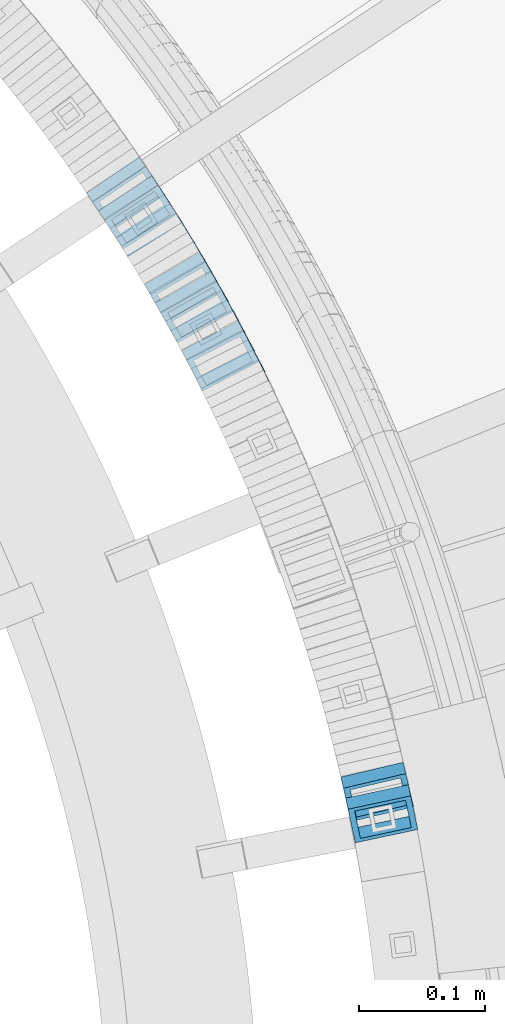
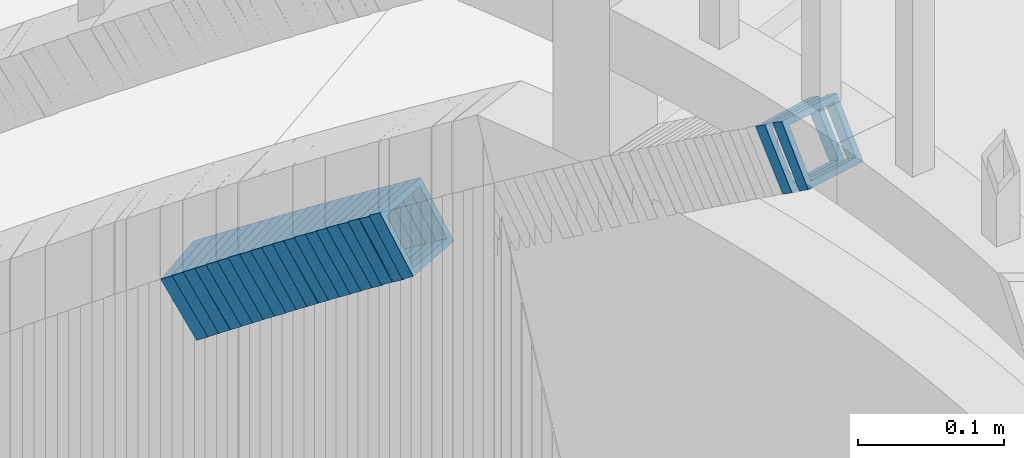
# One storey, part 801 of 975: 22 members.
"""IFC2X3 building model written with IfcOpenShell, lengths in millimetres."""

from ifc_helpers import new_model, si_unit, frame, origin_with_axes, place, context, subcontext, project, spatial, faceted_brep, material, type_object, element, save


model = new_model("IFC2X3")

# Units and contexts
model_context = context("Model", 3, precision=1e-05, world=origin_with_axes())
body_context = subcontext(model_context, "Body", "Model", "MODEL_VIEW")
ifc_project = project(units=[si_unit("LENGTHUNIT", "METRE", prefix="MILLI"), si_unit("AREAUNIT", "SQUARE_METRE"), si_unit("VOLUMEUNIT", "CUBIC_METRE"), si_unit("MASSUNIT", "GRAM", prefix="KILO"), si_unit("TIMEUNIT", "SECOND"), si_unit("PLANEANGLEUNIT", "RADIAN"), si_unit("SOLIDANGLEUNIT", "STERADIAN"), si_unit("THERMODYNAMICTEMPERATUREUNIT", "DEGREE_CELSIUS"), si_unit("LUMINOUSINTENSITYUNIT", "LUMEN")], contexts=[model_context])

# Site, building, storey
site_placement = place(None, origin_with_axes())
site = spatial("IfcSite", under=ifc_project, at=site_placement, CompositionType="ELEMENT")
building_placement = place(site_placement, origin_with_axes())
building = spatial("IfcBuilding", under=site, at=building_placement, Name="Undefined", CompositionType="ELEMENT")
storey_placement = place(building_placement, origin_with_axes())
storey = spatial("IfcBuildingStorey", under=building, at=storey_placement, Name="Undefined", CompositionType="ELEMENT", Elevation=0.0)

# Members
ifc_material = material()
member_type = type_object("IfcMemberType", Name="HSS2X2X.188_TUBES", PredefinedType="NOTDEFINED")
member_1_placement = place(storey_placement, frame((35981.5618450438, 4033.38886337004, 2043.37988730919), z_axis=(0.894427191057652, 0.447213595384486, -2.02726596398862e-10), x_axis=(0.377140378815216, -0.754280757630261, 0.537425039736552)))
element("IfcMember", 1, at=member_1_placement, inside=storey, type_object=member_type, material=ifc_material, Name="WALL", ObjectType="HSS2X2X.188_TUBES", context=body_context, shape_type="Brep", body=[
    faceted_brep([(0.0, 20.6374999999753, -20.6375000000298), (0.0, -20.6375000000153, -20.6375000000153), (10.6061303028146, -20.6374999999571, -20.6374999999643), (10.6061303027491, 20.6374999999971, -20.6375000000007), (0.0, -20.6374999999825, 20.6375000000335), (10.6061303027855, -20.6374999999825, 20.6375000000116), (0.0, 20.6375000000116, 20.6375000000189), (10.6061303027236, 20.637499999968, 20.6374999999716), (0.0, 25.3999999999724, -25.4000000000342), (0.0, 25.400000000016, 25.4000000000196), (10.6061303027163, 25.3999999999651, 25.3999999999651), (10.6061303027454, 25.3999999999942, -25.4000000000051), (0.0, -25.399999999976, 25.4000000000378), (10.6061303027891, -25.3999999999796, 25.4000000000124), (0.0, -25.400000000016, -25.4000000000196), (10.6061303028182, -25.3999999999505, -25.3999999999542)], [[[0, 1, 2, 3]], [[1, 4, 5, 2]], [[4, 6, 7, 5]], [[6, 0, 3, 7]], [[8, 9, 10, 11]], [[9, 12, 13, 10]], [[12, 14, 15, 13]], [[14, 8, 11, 15]], [[13, 15, 11, 10], [5, 7, 3, 2]], [[14, 12, 9, 8], [6, 4, 1, 0]]]),
])
member_2_placement = place(storey_placement, frame((35978.0339853726, 4040.73445227376, 2037.68657470446), z_axis=(0.882970965834001, 0.469427601973053, -3.50903519574786e-11), x_axis=(0.393901973854072, -0.740910855724943, 0.543959868798056)))
element("IfcMember", 2, at=member_2_placement, inside=storey, type_object=member_type, material=ifc_material, Name="WALL", ObjectType="HSS2X2X.188_TUBES", context=body_context, shape_type="Brep", body=[
    faceted_brep([(0.0, 20.6374999999753, -20.6375000000298), (0.0, -20.6375000000153, -20.6375000000153), (10.6625512894789, -20.6374999999625, -20.6374999999389), (10.6625512893879, 20.6374999999789, -20.6375000000371), (0.0, -20.6374999999825, 20.6375000000335), (10.6625512894352, -20.6374999999989, 20.6375000000153), (0.0, 20.6375000000116, 20.6375000000189), (10.6625512893443, 20.6374999999443, 20.6374999999134), (0.0, 25.3999999999724, -25.4000000000342), (0.0, 25.400000000016, 25.4000000000196), (10.6625512893297, 25.3999999999342, 25.3999999998996), (10.6625512893916, 25.399999999976, -25.4000000000415), (0.0, -25.399999999976, 25.4000000000378), (10.6625512894389, -25.399999999996, 25.400000000016), (0.0, -25.400000000016, -25.4000000000196), (10.6625512894971, -25.3999999999523, -25.3999999999214)], [[[0, 1, 2, 3]], [[1, 4, 5, 2]], [[4, 6, 7, 5]], [[6, 0, 3, 7]], [[8, 9, 10, 11]], [[9, 12, 13, 10]], [[12, 14, 15, 13]], [[14, 8, 11, 15]], [[13, 15, 11, 10], [5, 7, 3, 2]], [[14, 12, 9, 8], [6, 4, 1, 0]]]),
])
member_3_placement = place(storey_placement, frame((35973.6409137543, 4048.89888570985, 2031.91027951642), z_axis=(0.887584423987997, 0.460645080614019, 2.15857426155708e-10), x_axis=(0.387916122953189, -0.74744813990964, 0.539298024934809)))
element("IfcMember", 3, at=member_3_placement, inside=storey, type_object=member_type, material=ifc_material, Name="WALL", ObjectType="HSS2X2X.188_TUBES", context=body_context, shape_type="Brep", body=[
    faceted_brep([(0.0, 20.6374999999753, -20.6375000000298), (0.0, -20.6375000000153, -20.6375000000153), (10.5744976239494, -20.6375000000207, -20.6375000000335), (10.5744976239657, 20.6375000000098, -20.637500000008), (0.0, -20.6374999999825, 20.6375000000335), (10.5744976239639, -20.6375000000244, 20.6374999999753), (0.0, 20.6375000000116, 20.6375000000189), (10.5744976239803, 20.6374999999989, 20.6374999999935), (0.0, 25.3999999999724, -25.4000000000342), (0.0, 25.400000000016, 25.4000000000196), (10.5744976239857, 25.4000000000051, 25.4000000000015), (10.5744976239675, 25.4000000000124, -25.4000000000051), (0.0, -25.399999999976, 25.4000000000378), (10.5744976239639, -25.4000000000287, 25.3999999999724), (0.0, -25.400000000016, -25.4000000000196), (10.5744976239494, -25.4000000000215, -25.4000000000378)], [[[0, 1, 2, 3]], [[1, 4, 5, 2]], [[4, 6, 7, 5]], [[6, 0, 3, 7]], [[8, 9, 10, 11]], [[9, 12, 13, 10]], [[12, 14, 15, 13]], [[14, 8, 11, 15]], [[13, 15, 11, 10], [5, 7, 3, 2]], [[14, 12, 9, 8], [6, 4, 1, 0]]]),
])
member_4_placement = place(storey_placement, frame((35969.7662629963, 4056.57258299768, 2026.14539123515), z_axis=(0.87832011815247, 0.478072975651868, 2.39966993831331e-10), x_axis=(0.403813726764552, -0.741890335567007, 0.535287963687582)))
element("IfcMember", 4, at=member_4_placement, inside=storey, type_object=member_type, material=ifc_material, Name="WALL", ObjectType="HSS2X2X.188_TUBES", context=body_context, shape_type="Brep", body=[
    faceted_brep([(0.0, 20.6374999999753, -20.6375000000298), (0.0, -20.6375000000153, -20.6375000000153), (10.648004507897, -20.6374999999862, -20.637499999968), (10.6480045078188, 20.6374999999771, -20.6375000000808), (0.0, -20.6374999999825, 20.6375000000335), (10.6480045079406, -20.6374999999698, 20.6375000001062), (0.0, 20.6375000000116, 20.6375000000189), (10.6480045078679, 20.6374999999935, 20.6375000000007), (0.0, 25.3999999999724, -25.4000000000342), (0.0, 25.400000000016, 25.4000000000196), (10.6480045078661, 25.3999999999905, 25.4000000000015), (10.648004507806, 25.3999999999705, -25.4000000000997), (0.0, -25.399999999976, 25.4000000000378), (10.6480045079552, -25.3999999999633, 25.4000000001288), (0.0, -25.400000000016, -25.4000000000196), (10.6480045078988, -25.3999999999814, -25.3999999999651)], [[[0, 1, 2, 3]], [[1, 4, 5, 2]], [[4, 6, 7, 5]], [[6, 0, 3, 7]], [[8, 9, 10, 11]], [[9, 12, 13, 10]], [[12, 14, 15, 13]], [[14, 8, 11, 15]], [[13, 15, 11, 10], [5, 7, 3, 2]], [[14, 12, 9, 8], [6, 4, 1, 0]]]),
])
member_5_placement = place(storey_placement, frame((35965.6077390635, 4064.16544049647, 2020.54937689435), z_axis=(0.880471099958747, 0.474099822967098, 6.16046236245893e-12), x_axis=(0.396650262230548, -0.736636201428549, 0.547755124318665)))
element("IfcMember", 5, at=member_5_placement, inside=storey, type_object=member_type, material=ifc_material, Name="WALL", ObjectType="HSS2X2X.188_TUBES", context=body_context, shape_type="Brep", body=[
    faceted_brep([(0.0, 20.6374999999753, -20.6375000000298), (0.0, -20.6375000000153, -20.6375000000153), (10.5948100501191, -20.6375000000335, -20.6375000000844), (10.5948100501555, 20.6374999999971, -20.6375000000116), (0.0, -20.6374999999825, 20.6375000000335), (10.5948100501446, -20.6375000000098, 20.6374999999571), (0.0, 20.6375000000116, 20.6375000000189), (10.5948100501828, 20.6375000000189, 20.6375000000298), (0.0, 25.3999999999724, -25.4000000000342), (0.0, 25.400000000016, 25.4000000000196), (10.5948100501919, 25.4000000000251, 25.4000000000451), (10.5948100501591, 25.3999999999978, -25.4000000000051), (0.0, -25.399999999976, 25.4000000000378), (10.5948100501482, -25.4000000000106, 25.3999999999578), (0.0, -25.400000000016, -25.4000000000196), (10.5948100501118, -25.4000000000378, -25.400000000096)], [[[0, 1, 2, 3]], [[1, 4, 5, 2]], [[4, 6, 7, 5]], [[6, 0, 3, 7]], [[8, 9, 10, 11]], [[9, 12, 13, 10]], [[12, 14, 15, 13]], [[14, 8, 11, 15]], [[13, 15, 11, 10], [5, 7, 3, 2]], [[14, 12, 9, 8], [6, 4, 1, 0]]]),
])
member_6_placement = place(storey_placement, frame((35961.441688119, 4072.00477558925, 2014.70596512645), z_axis=(0.875741388818649, 0.482780509041101, -7.90664671512786e-11), x_axis=(0.406638703138548, -0.737623694251148, 0.539032699183537)))
element("IfcMember", 6, at=member_6_placement, inside=storey, type_object=member_type, material=ifc_material, Name="WALL", ObjectType="HSS2X2X.188_TUBES", context=body_context, shape_type="Brep", body=[
    faceted_brep([(0.0, 20.6374999999753, -20.6375000000298), (0.0, -20.6375000000153, -20.6375000000153), (10.5744976239494, -20.6375000000207, -20.6375000000335), (10.5744976239657, 20.6375000000098, -20.637500000008), (0.0, -20.6374999999825, 20.6375000000335), (10.5744976239639, -20.6375000000244, 20.6374999999753), (0.0, 20.6375000000116, 20.6375000000189), (10.5744976239803, 20.6374999999989, 20.6374999999935), (0.0, 25.3999999999724, -25.4000000000342), (0.0, 25.400000000016, 25.4000000000196), (10.5744976239857, 25.4000000000051, 25.4000000000015), (10.5744976239675, 25.4000000000124, -25.4000000000051), (0.0, -25.399999999976, 25.4000000000378), (10.5744976239639, -25.4000000000287, 25.3999999999724), (0.0, -25.400000000016, -25.4000000000196), (10.5744976239494, -25.4000000000215, -25.4000000000378)], [[[0, 1, 2, 3]], [[1, 4, 5, 2]], [[4, 6, 7, 5]], [[6, 0, 3, 7]], [[8, 9, 10, 11]], [[9, 12, 13, 10]], [[12, 14, 15, 13]], [[14, 8, 11, 15]], [[13, 15, 11, 10], [5, 7, 3, 2]], [[14, 12, 9, 8], [6, 4, 1, 0]]]),
])
for number, where, z_axis, x_axis, name in (
    (7, (35957.2535833107, 4079.69917479602, 2008.97216907642), (0.870978467909843, 0.491321186636015, 1.7358570403303e-10), (0.414486115154928, -0.734770841274942, 0.536947922200924), "WALL"),
    (8, (35952.8535833107, 4087.49917479601, 2003.27216907639), (0.870978467909843, 0.491321186636015, 1.7358570403303e-10), (0.414486115154928, -0.734770841274942, 0.536947922200924), "WALL"),
):
    element("IfcMember", number, at=place(storey_placement, frame(where, z_axis=z_axis, x_axis=x_axis)), inside=storey, type_object=member_type, material=ifc_material, Name=name, ObjectType="HSS2X2X.188_TUBES", context=body_context, shape_type="Brep", body=[
        faceted_brep([(0.0, 20.6374999999753, -20.6375000000298), (0.0, -20.6375000000153, -20.6375000000153), (10.6216759506497, -20.637499999968, -20.6374999999534), (10.6216759506497, 20.6375000000262, -20.6374999999643), (0.0, -20.6374999999825, 20.6375000000335), (10.6216759506169, -20.6374999999935, 20.637500000008), (0.0, 20.6375000000116, 20.6375000000189), (10.6216759506242, 20.6375000000007, 20.6374999999971), (0.0, 25.3999999999724, -25.4000000000342), (0.0, 25.400000000016, 25.4000000000196), (10.6216759506169, 25.3999999999978, 25.3999999999869), (10.6216759506533, 25.4000000000269, -25.3999999999614), (0.0, -25.399999999976, 25.4000000000378), (10.6216759506242, -25.3999999999942, 25.4000000000051), (0.0, -25.400000000016, -25.4000000000196), (10.6216759506569, -25.3999999999614, -25.3999999999432)], [[[0, 1, 2, 3]], [[1, 4, 5, 2]], [[4, 6, 7, 5]], [[6, 0, 3, 7]], [[8, 9, 10, 11]], [[9, 12, 13, 10]], [[12, 14, 15, 13]], [[14, 8, 11, 15]], [[13, 15, 11, 10], [5, 7, 3, 2]], [[14, 12, 9, 8], [6, 4, 1, 0]]]),
    ])
member_7_placement = place(storey_placement, frame((35948.8330101888, 4094.78583107829, 1997.60676413792), z_axis=(0.863371944159825, 0.504568019237926, -8.114466254483e-11), x_axis=(0.422987632021024, -0.723778837035465, 0.545184059026708)))
element("IfcMember", 9, at=member_7_placement, inside=storey, type_object=member_type, material=ifc_material, Name="WALL", ObjectType="HSS2X2X.188_TUBES", context=body_context, shape_type="Brep", body=[
    faceted_brep([(0.0, 20.6374999999753, -20.6375000000298), (0.0, -20.6375000000153, -20.6375000000153), (10.6395488625676, -20.6374999999771, -20.6374999999716), (10.6395488625531, 20.6374999999916, -20.6375000000189), (0.0, -20.6374999999825, 20.6375000000335), (10.6395488625731, -20.6374999999844, 20.6375000000153), (0.0, 20.6375000000116, 20.6375000000189), (10.6395488625585, 20.6374999999825, 20.637499999968), (0.0, 25.3999999999724, -25.4000000000342), (0.0, 25.400000000016, 25.4000000000196), (10.6395488625567, 25.3999999999778, 25.3999999999614), (10.6395488625494, 25.3999999999887, -25.4000000000233), (0.0, -25.399999999976, 25.4000000000378), (10.6395488625749, -25.3999999999851, 25.400000000016), (0.0, -25.400000000016, -25.4000000000196), (10.6395488625658, -25.399999999976, -25.3999999999687)], [[[0, 1, 2, 3]], [[1, 4, 5, 2]], [[4, 6, 7, 5]], [[6, 0, 3, 7]], [[8, 9, 10, 11]], [[9, 12, 13, 10]], [[12, 14, 15, 13]], [[14, 8, 11, 15]], [[13, 15, 11, 10], [5, 7, 3, 2]], [[14, 12, 9, 8], [6, 4, 1, 0]]]),
])
member_8_placement = place(storey_placement, frame((35939.8571150624, 4110.23570220285, 1986.06256360995), z_axis=(0.858475095883078, 0.512855252238427, -1.68183078130824e-10), x_axis=(0.432846529825112, -0.724547451707316, 0.536353308783299)))
element("IfcMember", 10, at=member_8_placement, inside=storey, type_object=member_type, material=ifc_material, Name="WALL", ObjectType="HSS2X2X.188_TUBES", context=body_context, shape_type="Brep", body=[
    faceted_brep([(0.0, 20.6374999999753, -20.6375000000298), (0.0, -20.6375000000153, -20.6375000000153), (10.6348483769107, -20.637499999988, -20.6374999999825), (10.6348483768415, 20.6374999999734, -20.6375000001026), (0.0, -20.6374999999825, 20.6375000000335), (10.6348483769852, -20.6374999999589, 20.6375000001462), (0.0, 20.6375000000116, 20.6375000000189), (10.6348483769161, 20.6375000000044, 20.6375000000226), (0.0, 25.3999999999724, -25.4000000000342), (0.0, 25.400000000016, 25.4000000000196), (10.6348483769179, 25.4000000000015, 25.4000000000233), (10.6348483768288, 25.3999999999669, -25.4000000001324), (0.0, -25.399999999976, 25.4000000000378), (10.6348483769998, -25.3999999999505, 25.4000000001688), (0.0, -25.400000000016, -25.4000000000196), (10.6348483769107, -25.3999999999887, -25.3999999999833)], [[[0, 1, 2, 3]], [[1, 4, 5, 2]], [[4, 6, 7, 5]], [[6, 0, 3, 7]], [[8, 9, 10, 11]], [[9, 12, 13, 10]], [[12, 14, 15, 13]], [[14, 8, 11, 15]], [[13, 15, 11, 10], [5, 7, 3, 2]], [[14, 12, 9, 8], [6, 4, 1, 0]]]),
])
member_9_placement = place(storey_placement, frame((35944.2476963996, 4102.63181245084, 1991.79775449428), z_axis=(0.863371944159825, 0.504568019237926, -8.114466254483e-11), x_axis=(0.425153095937052, -0.727484185892214, 0.538527254920196)))
element("IfcMember", 11, at=member_9_placement, inside=storey, type_object=member_type, material=ifc_material, Name="WALL", ObjectType="HSS2X2X.188_TUBES", context=body_context, shape_type="Brep", body=[
    faceted_brep([(0.0, 20.6374999999753, -20.6375000000298), (0.0, -20.6375000000153, -20.6375000000153), (10.5806427026419, -20.6374999999607, -20.6374999999316), (10.5806427026473, 20.6375000000444, -20.6374999999207), (0.0, -20.6374999999825, 20.6375000000335), (10.5806427025509, -20.6375000000207, 20.6374999999643), (0.0, 20.6375000000116, 20.6375000000189), (10.5806427025545, 20.6374999999862, 20.6374999999716), (0.0, 25.3999999999724, -25.4000000000342), (0.0, 25.400000000016, 25.4000000000196), (10.5806427025436, 25.3999999999796, 25.3999999999614), (10.5806427026582, 25.4000000000542, -25.3999999999105), (0.0, -25.399999999976, 25.4000000000378), (10.5806427025418, -25.4000000000287, 25.3999999999542), (0.0, -25.400000000016, -25.4000000000196), (10.5806427026528, -25.3999999999542, -25.3999999999178)], [[[0, 1, 2, 3]], [[1, 4, 5, 2]], [[4, 6, 7, 5]], [[6, 0, 3, 7]], [[8, 9, 10, 11]], [[9, 12, 13, 10]], [[12, 14, 15, 13]], [[14, 8, 11, 15]], [[13, 15, 11, 10], [5, 7, 3, 2]], [[14, 12, 9, 8], [6, 4, 1, 0]]]),
])
member_10_placement = place(storey_placement, frame((35935.5359455191, 4117.5260957435, 1980.43158076907), z_axis=(0.85550007890286, 0.517802679596389, 1.8612809071783e-10), x_axis=(0.433576554102011, -0.716343872168839, 0.54668348112887)))
element("IfcMember", 12, at=member_10_placement, inside=storey, type_object=member_type, material=ifc_material, Name="WALL", ObjectType="HSS2X2X.188_TUBES", context=body_context, shape_type="Brep", body=[
    faceted_brep([(0.0, 20.6374999999753, -20.6375000000298), (0.0, -20.6375000000153, -20.6375000000153), (10.6061303028146, -20.6374999999571, -20.6374999999643), (10.6061303027491, 20.6374999999971, -20.6375000000007), (0.0, -20.6374999999825, 20.6375000000335), (10.6061303027855, -20.6374999999825, 20.6375000000116), (0.0, 20.6375000000116, 20.6375000000189), (10.6061303027236, 20.637499999968, 20.6374999999716), (0.0, 25.3999999999724, -25.4000000000342), (0.0, 25.400000000016, 25.4000000000196), (10.6061303027163, 25.3999999999651, 25.3999999999651), (10.6061303027454, 25.3999999999942, -25.4000000000051), (0.0, -25.399999999976, 25.4000000000378), (10.6061303027891, -25.3999999999796, 25.4000000000124), (0.0, -25.400000000016, -25.4000000000196), (10.6061303028182, -25.3999999999505, -25.3999999999542)], [[[0, 1, 2, 3]], [[1, 4, 5, 2]], [[4, 6, 7, 5]], [[6, 0, 3, 7]], [[8, 9, 10, 11]], [[9, 12, 13, 10]], [[12, 14, 15, 13]], [[14, 8, 11, 15]], [[13, 15, 11, 10], [5, 7, 3, 2]], [[14, 12, 9, 8], [6, 4, 1, 0]]]),
])
for number, where, z_axis, x_axis, name in (
    (13, (35930.9573595431, 4125.1803039019, 1974.58569585177), (0.850503552704234, 0.525969302181674, -1.9779372451012e-10), (0.443435693790188, -0.717044951661042, 0.537783713745803), "WALL"),
    (14, (35926.2573595431, 4132.7803039019, 1968.88569585174), (0.850503552704234, 0.525969302181674, -1.9779372451012e-10), (0.443435693790188, -0.717044951661042, 0.537783713745803), "WALL"),
):
    element("IfcMember", number, at=place(storey_placement, frame(where, z_axis=z_axis, x_axis=x_axis)), inside=storey, type_object=member_type, material=ifc_material, Name=name, ObjectType="HSS2X2X.188_TUBES", context=body_context, shape_type="Brep", body=[
        faceted_brep([(0.0, 20.6374999999753, -20.6375000000298), (0.0, -20.6375000000153, -20.6375000000153), (10.6004716875832, -20.6375000000153, -20.6375000000553), (10.6004716875814, 20.6374999999898, -20.6375000000444), (0.0, -20.6374999999825, 20.6375000000335), (10.6004716876068, -20.6375000000044, 20.6374999999862), (0.0, 20.6375000000116, 20.6375000000189), (10.6004716876032, 20.6374999999989, 20.6374999999971), (0.0, 25.3999999999724, -25.4000000000342), (0.0, 25.400000000016, 25.4000000000196), (10.600471687605, 25.4000000000015, 25.4000000000051), (10.6004716875814, 25.3999999999869, -25.4000000000487), (0.0, -25.399999999976, 25.4000000000378), (10.6004716876068, -25.4000000000015, 25.3999999999905), (0.0, -25.400000000016, -25.4000000000196), (10.6004716875814, -25.4000000000178, -25.4000000000669)], [[[0, 1, 2, 3]], [[1, 4, 5, 2]], [[4, 6, 7, 5]], [[6, 0, 3, 7]], [[8, 9, 10, 11]], [[9, 12, 13, 10]], [[12, 14, 15, 13]], [[14, 8, 11, 15]], [[13, 15, 11, 10], [5, 7, 3, 2]], [[14, 12, 9, 8], [6, 4, 1, 0]]]),
    ])
member_11_placement = place(storey_placement, frame((35921.7538866512, 4140.15070736848, 1963.15724534256), z_axis=(0.845488902900091, 0.533992991595209, -3.59136492988909e-10), x_axis=(0.448696118952046, -0.71043552092376, 0.542174476941839)))
element("IfcMember", 15, at=member_11_placement, inside=storey, type_object=member_type, material=ifc_material, Name="WALL", ObjectType="HSS2X2X.188_TUBES", context=body_context, shape_type="Brep", body=[
    faceted_brep([(0.0, 20.6374999999753, -20.6375000000298), (0.0, -20.6375000000153, -20.6375000000153), (10.6985980389491, -20.6375000000317, -20.6375000000698), (10.6985980389982, 20.6375000000116, -20.6374999999643), (0.0, -20.6374999999825, 20.6375000000335), (10.6985980389818, -20.6374999999989, 20.6374999999789), (0.0, 20.6375000000116, 20.6375000000189), (10.6985980390309, 20.6375000000407, 20.6375000000808), (0.0, 25.3999999999724, -25.4000000000342), (0.0, 25.400000000016, 25.4000000000196), (10.6985980390382, 25.4000000000487, 25.4000000000997), (10.6985980390036, 25.4000000000142, -25.3999999999542), (0.0, -25.399999999976, 25.4000000000378), (10.6985980389763, -25.4000000000033, 25.3999999999724), (0.0, -25.400000000016, -25.4000000000196), (10.6985980389418, -25.400000000036, -25.4000000000851)], [[[0, 1, 2, 3]], [[1, 4, 5, 2]], [[4, 6, 7, 5]], [[6, 0, 3, 7]], [[8, 9, 10, 11]], [[9, 12, 13, 10]], [[12, 14, 15, 13]], [[14, 8, 11, 15]], [[13, 15, 11, 10], [5, 7, 3, 2]], [[14, 12, 9, 8], [6, 4, 1, 0]]]),
])
member_12_placement = place(storey_placement, frame((35912.4615316414, 4154.90895245425, 1951.67831947012), z_axis=(0.837166200021127, 0.54694858400236, 6.20048012933692e-12), x_axis=(0.459128463950918, -0.702747648925327, 0.543458181942269)))
element("IfcMember", 16, at=member_12_placement, inside=storey, type_object=member_type, material=ifc_material, Name="WALL", ObjectType="HSS2X2X.188_TUBES", context=body_context, shape_type="Brep", body=[
    faceted_brep([(0.0, 20.6374999999753, -20.6375000000298), (0.0, -20.6375000000153, -20.6375000000153), (10.6709887076922, -20.6374999999844, -20.6374999999825), (10.6709887076995, 20.6375000000171, -20.6374999999753), (0.0, -20.6374999999825, 20.6375000000335), (10.6709887076922, -20.6374999999971, 20.6375000000153), (0.0, 20.6375000000116, 20.6375000000189), (10.6709887076941, 20.6375000000025, 20.6375000000189), (0.0, 25.3999999999724, -25.4000000000342), (0.0, 25.400000000016, 25.4000000000196), (10.6709887076959, 25.3999999999996, 25.4000000000233), (10.6709887077013, 25.4000000000178, -25.3999999999724), (0.0, -25.399999999976, 25.4000000000378), (10.6709887076904, -25.3999999999978, 25.400000000016), (0.0, -25.400000000016, -25.4000000000196), (10.6709887076959, -25.3999999999796, -25.3999999999796)], [[[0, 1, 2, 3]], [[1, 4, 5, 2]], [[4, 6, 7, 5]], [[6, 0, 3, 7]], [[8, 9, 10, 11]], [[9, 12, 13, 10]], [[12, 14, 15, 13]], [[14, 8, 11, 15]], [[13, 15, 11, 10], [5, 7, 3, 2]], [[14, 12, 9, 8], [6, 4, 1, 0]]]),
])
member_13_placement = place(storey_placement, frame((35907.4691028336, 4162.55042511935, 1945.86985948625), z_axis=(0.837166200021127, 0.54694858400236, 6.20048012933692e-12), x_axis=(0.461463976956455, -0.706322413933316, 0.536805034949324)))
element("IfcMember", 17, at=member_13_placement, inside=storey, type_object=member_type, material=ifc_material, Name="WALL", ObjectType="HSS2X2X.188_TUBES", context=body_context, shape_type="Brep", body=[
    faceted_brep([(0.0, 20.6374999999753, -20.6375000000298), (0.0, -20.6375000000153, -20.6375000000153), (10.6216759506497, -20.637499999968, -20.6374999999534), (10.6216759506497, 20.6375000000262, -20.6374999999643), (0.0, -20.6374999999825, 20.6375000000335), (10.6216759506169, -20.6374999999935, 20.637500000008), (0.0, 20.6375000000116, 20.6375000000189), (10.6216759506242, 20.6375000000007, 20.6374999999971), (0.0, 25.3999999999724, -25.4000000000342), (0.0, 25.400000000016, 25.4000000000196), (10.6216759506169, 25.3999999999978, 25.3999999999869), (10.6216759506533, 25.4000000000269, -25.3999999999614), (0.0, -25.399999999976, 25.4000000000378), (10.6216759506242, -25.3999999999942, 25.4000000000051), (0.0, -25.400000000016, -25.4000000000196), (10.6216759506569, -25.3999999999614, -25.3999999999432)], [[[0, 1, 2, 3]], [[1, 4, 5, 2]], [[4, 6, 7, 5]], [[6, 0, 3, 7]], [[8, 9, 10, 11]], [[9, 12, 13, 10]], [[12, 14, 15, 13]], [[14, 8, 11, 15]], [[13, 15, 11, 10], [5, 7, 3, 2]], [[14, 12, 9, 8], [6, 4, 1, 0]]]),
])
member_14_placement = place(storey_placement, frame((35917.0636066596, 4147.63162551474, 1957.40753291204), z_axis=(0.842271400700161, 0.539053696362977, -2.99166458717081e-10), x_axis=(0.454003483146863, -0.709380442229785, 0.539129136174618)))
element("IfcMember", 18, at=member_14_placement, inside=storey, type_object=member_type, material=ifc_material, Name="WALL", ObjectType="HSS2X2X.188_TUBES", context=body_context, shape_type="Brep", body=[
    faceted_brep([(0.0, 20.6374999999753, -20.6375000000298), (0.0, -20.6375000000153, -20.6375000000153), (10.5744976239494, -20.6375000000207, -20.6375000000335), (10.5744976239657, 20.6375000000098, -20.637500000008), (0.0, -20.6374999999825, 20.6375000000335), (10.5744976239639, -20.6375000000244, 20.6374999999753), (0.0, 20.6375000000116, 20.6375000000189), (10.5744976239803, 20.6374999999989, 20.6374999999935), (0.0, 25.3999999999724, -25.4000000000342), (0.0, 25.400000000016, 25.4000000000196), (10.5744976239857, 25.4000000000051, 25.4000000000015), (10.5744976239675, 25.4000000000124, -25.4000000000051), (0.0, -25.399999999976, 25.4000000000378), (10.5744976239639, -25.4000000000287, 25.3999999999724), (0.0, -25.400000000016, -25.4000000000196), (10.5744976239494, -25.4000000000215, -25.4000000000378)], [[[0, 1, 2, 3]], [[1, 4, 5, 2]], [[4, 6, 7, 5]], [[6, 0, 3, 7]], [[8, 9, 10, 11]], [[9, 12, 13, 10]], [[12, 14, 15, 13]], [[14, 8, 11, 15]], [[13, 15, 11, 10], [5, 7, 3, 2]], [[14, 12, 9, 8], [6, 4, 1, 0]]]),
])
member_15_placement = place(storey_placement, frame((35897.8799567859, 4177.21435622781, 1934.38918918745), z_axis=(0.828588968904645, 0.559857410962414, -1.41944838105701e-11), x_axis=(0.471929177978215, -0.698455183967551, 0.537999262975016)))
element("IfcMember", 19, at=member_15_placement, inside=storey, type_object=member_type, material=ifc_material, Name="WALL", ObjectType="HSS2X2X.188_TUBES", context=body_context, shape_type="Brep", body=[
    faceted_brep([(0.0, 20.6374999999753, -20.6375000000298), (0.0, -20.6375000000153, -20.6375000000153), (10.5948100501191, -20.6375000000335, -20.6375000000844), (10.5948100501555, 20.6374999999971, -20.6375000000116), (0.0, -20.6374999999825, 20.6375000000335), (10.5948100501446, -20.6375000000098, 20.6374999999571), (0.0, 20.6375000000116, 20.6375000000189), (10.5948100501828, 20.6375000000189, 20.6375000000298), (0.0, 25.3999999999724, -25.4000000000342), (0.0, 25.400000000016, 25.4000000000196), (10.5948100501919, 25.4000000000251, 25.4000000000451), (10.5948100501591, 25.3999999999978, -25.4000000000051), (0.0, -25.399999999976, 25.4000000000378), (10.5948100501482, -25.4000000000106, 25.3999999999578), (0.0, -25.400000000016, -25.4000000000196), (10.5948100501118, -25.4000000000378, -25.400000000096)], [[[0, 1, 2, 3]], [[1, 4, 5, 2]], [[4, 6, 7, 5]], [[6, 0, 3, 7]], [[8, 9, 10, 11]], [[9, 12, 13, 10]], [[12, 14, 15, 13]], [[14, 8, 11, 15]], [[13, 15, 11, 10], [5, 7, 3, 2]], [[14, 12, 9, 8], [6, 4, 1, 0]]]),
])
member_16_placement = place(storey_placement, frame((35902.7654163572, 4169.83227256578, 1940.1398505823), z_axis=(0.832050294630691, 0.554700195785959, -1.70329258253332e-10), x_axis=(0.466475554081776, -0.699713332123146, 0.541111643095234)))
element("IfcMember", 20, at=member_16_placement, inside=storey, type_object=member_type, material=ifc_material, Name="WALL", ObjectType="HSS2X2X.188_TUBES", context=body_context, shape_type="Brep", body=[
    faceted_brep([(0.0, 20.6374999999753, -20.6375000000298), (0.0, -20.6375000000153, -20.6375000000153), (10.7247377590011, -20.6375000000189, -20.6375000000589), (10.7247377589938, 20.6374999999844, -20.6375000000698), (0.0, -20.6374999999825, 20.6375000000335), (10.7247377590484, -20.6374999999771, 20.6375000000517), (0.0, 20.6375000000116, 20.6375000000189), (10.7247377590447, 20.6375000000262, 20.6375000000407), (0.0, 25.3999999999724, -25.4000000000342), (0.0, 25.400000000016, 25.4000000000196), (10.7247377590484, 25.4000000000342, 25.400000000056), (10.7247377589902, 25.3999999999778, -25.4000000000851), (0.0, -25.399999999976, 25.4000000000378), (10.7247377590556, -25.3999999999724, 25.4000000000633), (0.0, -25.400000000016, -25.4000000000196), (10.7247377589938, -25.4000000000251, -25.4000000000742)], [[[0, 1, 2, 3]], [[1, 4, 5, 2]], [[4, 6, 7, 5]], [[6, 0, 3, 7]], [[8, 9, 10, 11]], [[9, 12, 13, 10]], [[12, 14, 15, 13]], [[14, 8, 11, 15]], [[13, 15, 11, 10], [5, 7, 3, 2]], [[14, 12, 9, 8], [6, 4, 1, 0]]]),
])
member_17_placement = place(storey_placement, frame((36099.0787025805, 3703.2834453978, 2272.45066397805), z_axis=(0.973273559019952, 0.229648817355188, -2.16356966120657e-10), x_axis=(0.193929710942592, -0.821892583757557, 0.535615391841992)))
element("IfcMember", 21, at=member_17_placement, inside=storey, type_object=member_type, material=ifc_material, Name="WALL", ObjectType="HSS2X2X.188_TUBES", context=body_context, shape_type="Brep", body=[
    faceted_brep([(0.0, 20.6374999999753, -20.6375000000298), (0.0, -20.6375000000153, -20.6375000000153), (10.8286656611563, -20.637499999988, -20.6375000001281), (10.8286656611217, 20.6374999999989, -20.6374999999971), (0.0, -20.6374999999825, 20.6375000000335), (10.8286656611235, -20.6374999999989, 20.6374999999971), (0.0, 20.6375000000116, 20.6375000000189), (10.828665661089, 20.6374999999898, 20.6375000001353), (0.0, 25.3999999999724, -25.4000000000342), (0.0, 25.400000000016, 25.4000000000196), (10.8286656610817, 25.3999999999869, 25.4000000001543), (10.8286656611199, 25.3999999999996, -25.3999999999942), (0.0, -25.399999999976, 25.4000000000378), (10.8286656611235, -25.3999999999978, 25.3999999999942), (0.0, -25.400000000016, -25.4000000000196), (10.8286656611617, -25.3999999999851, -25.4000000001615)], [[[0, 1, 2, 3]], [[1, 4, 5, 2]], [[4, 6, 7, 5]], [[6, 0, 3, 7]], [[8, 9, 10, 11]], [[9, 12, 13, 10]], [[12, 14, 15, 13]], [[14, 8, 11, 15]], [[13, 15, 11, 10], [5, 7, 3, 2]], [[14, 12, 9, 8], [6, 4, 1, 0]]]),
])
member_18_placement = place(storey_placement, frame((36102.7853999159, 3686.00413237319, 2284.18032207211), z_axis=(0.977962931156075, 0.208778603512472, -2.98646227747667e-10), x_axis=(0.176061828898426, -0.824710670523334, 0.537451897689361)))
element("IfcMember", 22, at=member_18_placement, inside=storey, type_object=member_type, material=ifc_material, Name="WALL", ObjectType="HSS2X2X.188_TUBES", context=body_context, shape_type="Brep", body=[
    faceted_brep([(0.0, 20.6374999999753, -20.6375000000298), (0.0, -20.6375000000153, -20.6375000000153), (10.7916634491794, -20.6374999999983, -20.6375000000116), (10.791663449163, 20.6374999999836, -20.6375000001572), (0.0, -20.6374999999825, 20.6375000000335), (10.7916634491967, -20.6374999999803, 20.6375000001353), (0.0, 20.6375000000116, 20.6375000000189), (10.7916634491803, 20.6375000000002, 20.6374999999898), (0.0, 25.3999999999724, -25.4000000000342), (0.0, 25.400000000016, 25.4000000000196), (10.7916634491803, 25.4000000000005, 25.3999999999869), (10.7916634491603, 25.3999999999796, -25.4000000001906), (0.0, -25.399999999976, 25.4000000000378), (10.7916634492012, -25.3999999999758, 25.4000000001688), (0.0, -25.400000000016, -25.4000000000196), (10.7916634491785, -25.3999999999981, -25.4000000000233)], [[[0, 1, 2, 3]], [[1, 4, 5, 2]], [[4, 6, 7, 5]], [[6, 0, 3, 7]], [[8, 9, 10, 11]], [[9, 12, 13, 10]], [[12, 14, 15, 13]], [[14, 8, 11, 15]], [[13, 15, 11, 10], [5, 7, 3, 2]], [[14, 12, 9, 8], [6, 4, 1, 0]]]),
])

save(model, "model.ifc")
